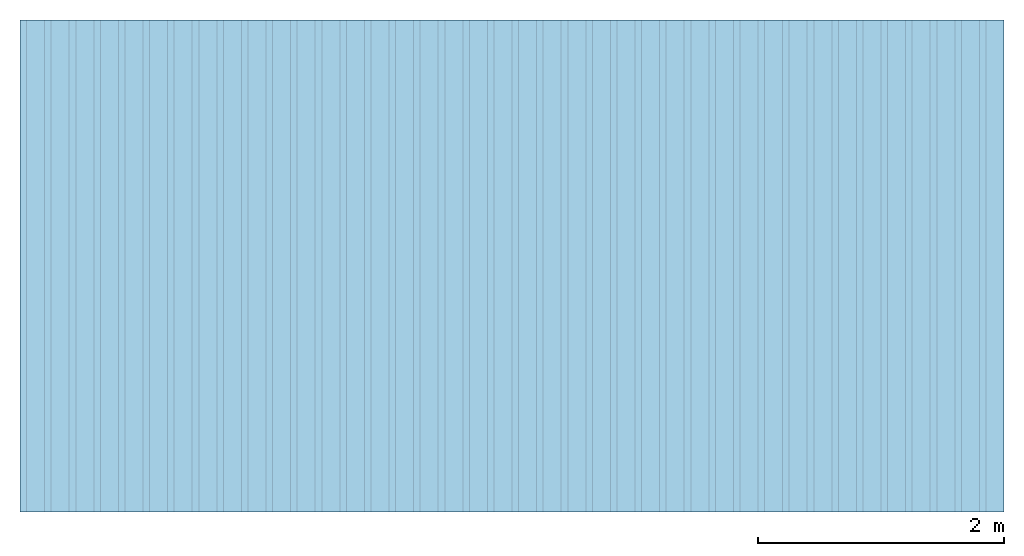
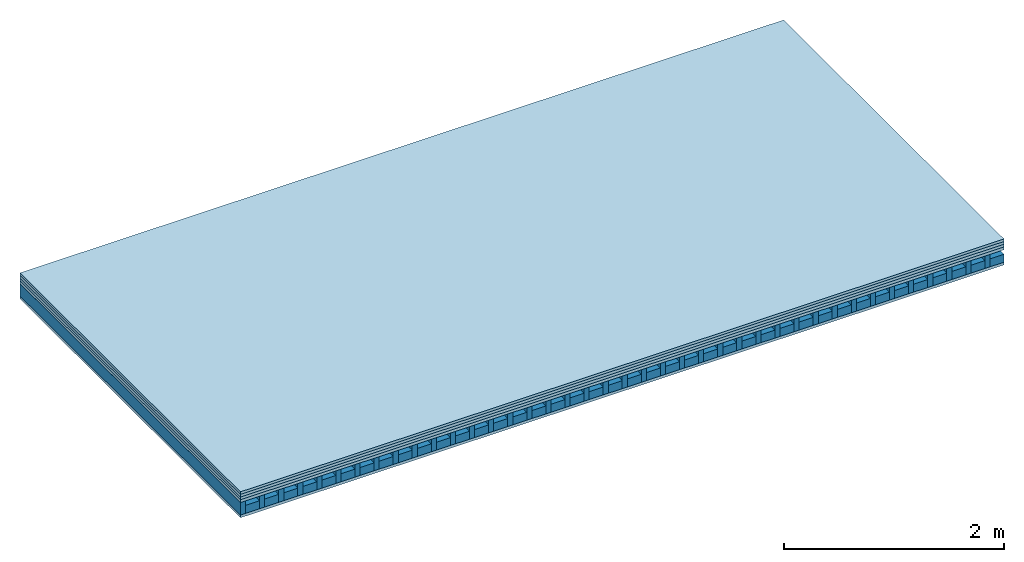
# One storey: 5 plates, 2 members, 1 element without a shape of its own.
"""IFC4 building model written with IfcOpenShell, lengths in metres."""

from ifc_helpers import new_model, si_unit, derived_unit, direction, frame, frame_2d, origin, origin_with_axes, place, context, project, spatial, rectangle, extrude, material, layer, layer_set, type_object, element, aggregate, save


model = new_model("IFC4")

# Units and contexts
plan_context = context("Plan", 3, precision=1e-05, world=origin(), true_north=direction((0.0, 1.0)))
model_context = context("Model", 3, precision=1e-05, world=origin(), true_north=direction((0.0, 1.0)))
ifc_project = project(units=[si_unit("LENGTHUNIT", "METRE"), derived_unit("SOUNDPRESSUREUNIT", [(si_unit("PRESSUREUNIT", "PASCAL", prefix="MICRO"), 0)]), si_unit("ENERGYUNIT", "JOULE", prefix="MEGA"), si_unit("MASSUNIT", "GRAM", prefix="KILO"), derived_unit("THERMALTRANSMITTANCEUNIT", [(si_unit("POWERUNIT", "WATT"), 1), (si_unit("AREAUNIT", "SQUARE_METRE"), -1), (si_unit("THERMODYNAMICTEMPERATUREUNIT", "KELVIN"), -1)]), derived_unit("AREADENSITYUNIT", [(si_unit("MASSUNIT", "GRAM", prefix="KILO"), 1), (si_unit("AREAUNIT", "SQUARE_METRE"), -1)]), derived_unit("USERDEFINED", [(si_unit("ENERGYUNIT", "JOULE", prefix="MEGA"), 1), (si_unit("AREAUNIT", "SQUARE_METRE"), -1)])], contexts=[plan_context, model_context])

# Site, building, storey
site = spatial("IfcSite", under=ifc_project)
building_placement = place(None, origin())
building = spatial("IfcBuilding", under=site, at=building_placement)
storey_placement = place(building_placement, origin())
storey = spatial("IfcBuildingStorey", under=building, at=storey_placement)

# Slab, members, plates
ifc_material_1 = material(Name="P2 ECO", Category="07.015")
ifc_layer_1 = layer(ifc_material_1, 0.028, Name="On-material")
ifc_material_2 = material(Name="EP2, 30mm")
ifc_layer_2 = layer(ifc_material_2, 0.03, Name="Impact sound insulation")
ifc_material_3 = material(Category="03.011")
ifc_layer_3 = layer(ifc_material_3, 0.03, Name="on Supporting structure")
ifc_material_4 = material(Name="box-element sheathing above")
ifc_layer_4 = layer(ifc_material_4, 0.031, Name="Sub-floor")
ifc_layer_5 = layer(None, 0.138, Name="Supporting structure")
ifc_material_5 = material(Name="box-element sheathing below")
ifc_layer_6 = layer(ifc_material_5, 0.031, Name="Lower layer 1")
ifc_layer_set = layer_set([ifc_layer_1, ifc_layer_2, ifc_layer_3, ifc_layer_4, ifc_layer_5, ifc_layer_6])
slab_type = type_object("IfcSlabType", Name="A1463", PredefinedType="NOTDEFINED", material=ifc_layer_set)
slab_placement = place(None, frame((0.0, 0.0, 0.0), z_axis=(0.0, 0.0, -1.0), x_axis=(1.0, 0.0, 0.0)))
slab = element("IfcSlab", 1, at=slab_placement, inside=storey, type_object=slab_type, material=ifc_layer_set, Name="Slab #1")
ifc_material_6 = material(Name="box-element LKE 12")
member_1_placement = place(slab_placement, origin())
member_1 = element("IfcMember", 2, at=member_1_placement, material=ifc_material_6, Name="Supporting structure", context=plan_context, shape_type="SweptSolid", body=[
    extrude(rectangle(XDim=0.054, YDim=0.138, at=frame_2d((0.027, 0.069), x_axis=(1.0, 0.0))), frame((0.0, 4.0, 0.119), z_axis=(0.0, -1.0, 0.0), x_axis=(1.0, 0.0, 0.0)), (0.0, 0.0, 1.0), 4.0),
    extrude(rectangle(XDim=0.054, YDim=0.138, at=frame_2d((0.027, 0.069), x_axis=(1.0, 0.0))), frame((0.2, 4.0, 0.119), z_axis=(0.0, -1.0, 0.0), x_axis=(1.0, 0.0, 0.0)), (0.0, 0.0, 1.0), 4.0),
    extrude(rectangle(XDim=0.054, YDim=0.138, at=frame_2d((0.027, 0.069), x_axis=(1.0, 0.0))), frame((0.4, 4.0, 0.119), z_axis=(0.0, -1.0, 0.0), x_axis=(1.0, 0.0, 0.0)), (0.0, 0.0, 1.0), 4.0),
    extrude(rectangle(XDim=0.054, YDim=0.138, at=frame_2d((0.027, 0.069), x_axis=(1.0, 0.0))), frame((0.6, 4.0, 0.119), z_axis=(0.0, -1.0, 0.0), x_axis=(1.0, 0.0, 0.0)), (0.0, 0.0, 1.0), 4.0),
    extrude(rectangle(XDim=0.054, YDim=0.138, at=frame_2d((0.027, 0.069), x_axis=(1.0, 0.0))), frame((0.8, 4.0, 0.119), z_axis=(0.0, -1.0, 0.0), x_axis=(1.0, 0.0, 0.0)), (0.0, 0.0, 1.0), 4.0),
    extrude(rectangle(XDim=0.054, YDim=0.138, at=frame_2d((0.027, 0.069), x_axis=(1.0, 0.0))), frame((1.0, 4.0, 0.119), z_axis=(0.0, -1.0, 0.0), x_axis=(1.0, 0.0, 0.0)), (0.0, 0.0, 1.0), 4.0),
    extrude(rectangle(XDim=0.054, YDim=0.138, at=frame_2d((0.027, 0.069), x_axis=(1.0, 0.0))), frame((1.2, 4.0, 0.119), z_axis=(0.0, -1.0, 0.0), x_axis=(1.0, 0.0, 0.0)), (0.0, 0.0, 1.0), 4.0),
    extrude(rectangle(XDim=0.054, YDim=0.138, at=frame_2d((0.027, 0.069), x_axis=(1.0, 0.0))), frame((1.4, 4.0, 0.119), z_axis=(0.0, -1.0, 0.0), x_axis=(1.0, 0.0, 0.0)), (0.0, 0.0, 1.0), 4.0),
    extrude(rectangle(XDim=0.054, YDim=0.138, at=frame_2d((0.027, 0.069), x_axis=(1.0, 0.0))), frame((1.6, 4.0, 0.119), z_axis=(0.0, -1.0, 0.0), x_axis=(1.0, 0.0, 0.0)), (0.0, 0.0, 1.0), 4.0),
    extrude(rectangle(XDim=0.054, YDim=0.138, at=frame_2d((0.027, 0.069), x_axis=(1.0, 0.0))), frame((1.8, 4.0, 0.119), z_axis=(0.0, -1.0, 0.0), x_axis=(1.0, 0.0, 0.0)), (0.0, 0.0, 1.0), 4.0),
    extrude(rectangle(XDim=0.054, YDim=0.138, at=frame_2d((0.027, 0.069), x_axis=(1.0, 0.0))), frame((2.0, 4.0, 0.119), z_axis=(0.0, -1.0, 0.0), x_axis=(1.0, 0.0, 0.0)), (0.0, 0.0, 1.0), 4.0),
    extrude(rectangle(XDim=0.054, YDim=0.138, at=frame_2d((0.027, 0.069), x_axis=(1.0, 0.0))), frame((2.2, 4.0, 0.119), z_axis=(0.0, -1.0, 0.0), x_axis=(1.0, 0.0, 0.0)), (0.0, 0.0, 1.0), 4.0),
    extrude(rectangle(XDim=0.054, YDim=0.138, at=frame_2d((0.027, 0.069), x_axis=(1.0, 0.0))), frame((2.4, 4.0, 0.119), z_axis=(0.0, -1.0, 0.0), x_axis=(1.0, 0.0, 0.0)), (0.0, 0.0, 1.0), 4.0),
    extrude(rectangle(XDim=0.054, YDim=0.138, at=frame_2d((0.027, 0.069), x_axis=(1.0, 0.0))), frame((2.6, 4.0, 0.119), z_axis=(0.0, -1.0, 0.0), x_axis=(1.0, 0.0, 0.0)), (0.0, 0.0, 1.0), 4.0),
    extrude(rectangle(XDim=0.054, YDim=0.138, at=frame_2d((0.027, 0.069), x_axis=(1.0, 0.0))), frame((2.8, 4.0, 0.119), z_axis=(0.0, -1.0, 0.0), x_axis=(1.0, 0.0, 0.0)), (0.0, 0.0, 1.0), 4.0),
    extrude(rectangle(XDim=0.054, YDim=0.138, at=frame_2d((0.027, 0.069), x_axis=(1.0, 0.0))), frame((3.0, 4.0, 0.119), z_axis=(0.0, -1.0, 0.0), x_axis=(1.0, 0.0, 0.0)), (0.0, 0.0, 1.0), 4.0),
    extrude(rectangle(XDim=0.054, YDim=0.138, at=frame_2d((0.027, 0.069), x_axis=(1.0, 0.0))), frame((3.2, 4.0, 0.119), z_axis=(0.0, -1.0, 0.0), x_axis=(1.0, 0.0, 0.0)), (0.0, 0.0, 1.0), 4.0),
    extrude(rectangle(XDim=0.054, YDim=0.138, at=frame_2d((0.027, 0.069), x_axis=(1.0, 0.0))), frame((3.4, 4.0, 0.119), z_axis=(0.0, -1.0, 0.0), x_axis=(1.0, 0.0, 0.0)), (0.0, 0.0, 1.0), 4.0),
    extrude(rectangle(XDim=0.054, YDim=0.138, at=frame_2d((0.027, 0.069), x_axis=(1.0, 0.0))), frame((3.6, 4.0, 0.119), z_axis=(0.0, -1.0, 0.0), x_axis=(1.0, 0.0, 0.0)), (0.0, 0.0, 1.0), 4.0),
    extrude(rectangle(XDim=0.054, YDim=0.138, at=frame_2d((0.027, 0.069), x_axis=(1.0, 0.0))), frame((3.8, 4.0, 0.119), z_axis=(0.0, -1.0, 0.0), x_axis=(1.0, 0.0, 0.0)), (0.0, 0.0, 1.0), 4.0),
    extrude(rectangle(XDim=0.054, YDim=0.138, at=frame_2d((0.027, 0.069), x_axis=(1.0, 0.0))), frame((4.0, 4.0, 0.119), z_axis=(0.0, -1.0, 0.0), x_axis=(1.0, 0.0, 0.0)), (0.0, 0.0, 1.0), 4.0),
    extrude(rectangle(XDim=0.054, YDim=0.138, at=frame_2d((0.027, 0.069), x_axis=(1.0, 0.0))), frame((4.2, 4.0, 0.119), z_axis=(0.0, -1.0, 0.0), x_axis=(1.0, 0.0, 0.0)), (0.0, 0.0, 1.0), 4.0),
    extrude(rectangle(XDim=0.054, YDim=0.138, at=frame_2d((0.027, 0.069), x_axis=(1.0, 0.0))), frame((4.4, 4.0, 0.119), z_axis=(0.0, -1.0, 0.0), x_axis=(1.0, 0.0, 0.0)), (0.0, 0.0, 1.0), 4.0),
    extrude(rectangle(XDim=0.054, YDim=0.138, at=frame_2d((0.027, 0.069), x_axis=(1.0, 0.0))), frame((4.6, 4.0, 0.119), z_axis=(0.0, -1.0, 0.0), x_axis=(1.0, 0.0, 0.0)), (0.0, 0.0, 1.0), 4.0),
    extrude(rectangle(XDim=0.054, YDim=0.138, at=frame_2d((0.027, 0.069), x_axis=(1.0, 0.0))), frame((4.8, 4.0, 0.119), z_axis=(0.0, -1.0, 0.0), x_axis=(1.0, 0.0, 0.0)), (0.0, 0.0, 1.0), 4.0),
    extrude(rectangle(XDim=0.054, YDim=0.138, at=frame_2d((0.027, 0.069), x_axis=(1.0, 0.0))), frame((5.0, 4.0, 0.119), z_axis=(0.0, -1.0, 0.0), x_axis=(1.0, 0.0, 0.0)), (0.0, 0.0, 1.0), 4.0),
    extrude(rectangle(XDim=0.054, YDim=0.138, at=frame_2d((0.027, 0.069), x_axis=(1.0, 0.0))), frame((5.2, 4.0, 0.119), z_axis=(0.0, -1.0, 0.0), x_axis=(1.0, 0.0, 0.0)), (0.0, 0.0, 1.0), 4.0),
    extrude(rectangle(XDim=0.054, YDim=0.138, at=frame_2d((0.027, 0.069), x_axis=(1.0, 0.0))), frame((5.4, 4.0, 0.119), z_axis=(0.0, -1.0, 0.0), x_axis=(1.0, 0.0, 0.0)), (0.0, 0.0, 1.0), 4.0),
    extrude(rectangle(XDim=0.054, YDim=0.138, at=frame_2d((0.027, 0.069), x_axis=(1.0, 0.0))), frame((5.6, 4.0, 0.119), z_axis=(0.0, -1.0, 0.0), x_axis=(1.0, 0.0, 0.0)), (0.0, 0.0, 1.0), 4.0),
    extrude(rectangle(XDim=0.054, YDim=0.138, at=frame_2d((0.027, 0.069), x_axis=(1.0, 0.0))), frame((5.8, 4.0, 0.119), z_axis=(0.0, -1.0, 0.0), x_axis=(1.0, 0.0, 0.0)), (0.0, 0.0, 1.0), 4.0),
    extrude(rectangle(XDim=0.054, YDim=0.138, at=frame_2d((0.027, 0.069), x_axis=(1.0, 0.0))), frame((6.0, 4.0, 0.119), z_axis=(0.0, -1.0, 0.0), x_axis=(1.0, 0.0, 0.0)), (0.0, 0.0, 1.0), 4.0),
    extrude(rectangle(XDim=0.054, YDim=0.138, at=frame_2d((0.027, 0.069), x_axis=(1.0, 0.0))), frame((6.2, 4.0, 0.119), z_axis=(0.0, -1.0, 0.0), x_axis=(1.0, 0.0, 0.0)), (0.0, 0.0, 1.0), 4.0),
    extrude(rectangle(XDim=0.054, YDim=0.138, at=frame_2d((0.027, 0.069), x_axis=(1.0, 0.0))), frame((6.4, 4.0, 0.119), z_axis=(0.0, -1.0, 0.0), x_axis=(1.0, 0.0, 0.0)), (0.0, 0.0, 1.0), 4.0),
    extrude(rectangle(XDim=0.054, YDim=0.138, at=frame_2d((0.027, 0.069), x_axis=(1.0, 0.0))), frame((6.6, 4.0, 0.119), z_axis=(0.0, -1.0, 0.0), x_axis=(1.0, 0.0, 0.0)), (0.0, 0.0, 1.0), 4.0),
    extrude(rectangle(XDim=0.054, YDim=0.138, at=frame_2d((0.027, 0.069), x_axis=(1.0, 0.0))), frame((6.8, 4.0, 0.119), z_axis=(0.0, -1.0, 0.0), x_axis=(1.0, 0.0, 0.0)), (0.0, 0.0, 1.0), 4.0),
    extrude(rectangle(XDim=0.054, YDim=0.138, at=frame_2d((0.027, 0.069), x_axis=(1.0, 0.0))), frame((7.0, 4.0, 0.119), z_axis=(0.0, -1.0, 0.0), x_axis=(1.0, 0.0, 0.0)), (0.0, 0.0, 1.0), 4.0),
    extrude(rectangle(XDim=0.054, YDim=0.138, at=frame_2d((0.027, 0.069), x_axis=(1.0, 0.0))), frame((7.2, 4.0, 0.119), z_axis=(0.0, -1.0, 0.0), x_axis=(1.0, 0.0, 0.0)), (0.0, 0.0, 1.0), 4.0),
    extrude(rectangle(XDim=0.054, YDim=0.138, at=frame_2d((0.027, 0.069), x_axis=(1.0, 0.0))), frame((7.4, 4.0, 0.119), z_axis=(0.0, -1.0, 0.0), x_axis=(1.0, 0.0, 0.0)), (0.0, 0.0, 1.0), 4.0),
    extrude(rectangle(XDim=0.054, YDim=0.138, at=frame_2d((0.027, 0.069), x_axis=(1.0, 0.0))), frame((7.6, 4.0, 0.119), z_axis=(0.0, -1.0, 0.0), x_axis=(1.0, 0.0, 0.0)), (0.0, 0.0, 1.0), 4.0),
    extrude(rectangle(XDim=0.054, YDim=0.138, at=frame_2d((0.027, 0.069), x_axis=(1.0, 0.0))), frame((7.8, 4.0, 0.119), z_axis=(0.0, -1.0, 0.0), x_axis=(1.0, 0.0, 0.0)), (0.0, 0.0, 1.0), 4.0),
])
ifc_material_7 = material(Name="Damper and limestone LKE 12")
member_2_placement = place(slab_placement, origin())
member_2 = element("IfcMember", 3, at=member_2_placement, material=ifc_material_7, Name="in supporting structure", context=plan_context, shape_type="SweptSolid", body=[
    extrude(rectangle(XDim=0.146, YDim=0.088, at=frame_2d((0.073, 0.044), x_axis=(1.0, 0.0))), frame((0.054, 4.0, 0.169), z_axis=(0.0, -1.0, 0.0), x_axis=(1.0, 0.0, 0.0)), (0.0, 0.0, 1.0), 4.0),
    extrude(rectangle(XDim=0.146, YDim=0.088, at=frame_2d((0.073, 0.044), x_axis=(1.0, 0.0))), frame((0.254, 4.0, 0.169), z_axis=(0.0, -1.0, 0.0), x_axis=(1.0, 0.0, 0.0)), (0.0, 0.0, 1.0), 4.0),
    extrude(rectangle(XDim=0.146, YDim=0.088, at=frame_2d((0.073, 0.044), x_axis=(1.0, 0.0))), frame((0.454, 4.0, 0.169), z_axis=(0.0, -1.0, 0.0), x_axis=(1.0, 0.0, 0.0)), (0.0, 0.0, 1.0), 4.0),
    extrude(rectangle(XDim=0.146, YDim=0.088, at=frame_2d((0.073, 0.044), x_axis=(1.0, 0.0))), frame((0.654, 4.0, 0.169), z_axis=(0.0, -1.0, 0.0), x_axis=(1.0, 0.0, 0.0)), (0.0, 0.0, 1.0), 4.0),
    extrude(rectangle(XDim=0.146, YDim=0.088, at=frame_2d((0.073, 0.044), x_axis=(1.0, 0.0))), frame((0.854, 4.0, 0.169), z_axis=(0.0, -1.0, 0.0), x_axis=(1.0, 0.0, 0.0)), (0.0, 0.0, 1.0), 4.0),
    extrude(rectangle(XDim=0.146, YDim=0.088, at=frame_2d((0.073, 0.044), x_axis=(1.0, 0.0))), frame((1.054, 4.0, 0.169), z_axis=(0.0, -1.0, 0.0), x_axis=(1.0, 0.0, 0.0)), (0.0, 0.0, 1.0), 4.0),
    extrude(rectangle(XDim=0.146, YDim=0.088, at=frame_2d((0.073, 0.044), x_axis=(1.0, 0.0))), frame((1.254, 4.0, 0.169), z_axis=(0.0, -1.0, 0.0), x_axis=(1.0, 0.0, 0.0)), (0.0, 0.0, 1.0), 4.0),
    extrude(rectangle(XDim=0.146, YDim=0.088, at=frame_2d((0.073, 0.044), x_axis=(1.0, 0.0))), frame((1.454, 4.0, 0.169), z_axis=(0.0, -1.0, 0.0), x_axis=(1.0, 0.0, 0.0)), (0.0, 0.0, 1.0), 4.0),
    extrude(rectangle(XDim=0.146, YDim=0.088, at=frame_2d((0.073, 0.044), x_axis=(1.0, 0.0))), frame((1.654, 4.0, 0.169), z_axis=(0.0, -1.0, 0.0), x_axis=(1.0, 0.0, 0.0)), (0.0, 0.0, 1.0), 4.0),
    extrude(rectangle(XDim=0.146, YDim=0.088, at=frame_2d((0.073, 0.044), x_axis=(1.0, 0.0))), frame((1.854, 4.0, 0.169), z_axis=(0.0, -1.0, 0.0), x_axis=(1.0, 0.0, 0.0)), (0.0, 0.0, 1.0), 4.0),
    extrude(rectangle(XDim=0.146, YDim=0.088, at=frame_2d((0.073, 0.044), x_axis=(1.0, 0.0))), frame((2.054, 4.0, 0.169), z_axis=(0.0, -1.0, 0.0), x_axis=(1.0, 0.0, 0.0)), (0.0, 0.0, 1.0), 4.0),
    extrude(rectangle(XDim=0.146, YDim=0.088, at=frame_2d((0.073, 0.044), x_axis=(1.0, 0.0))), frame((2.254, 4.0, 0.169), z_axis=(0.0, -1.0, 0.0), x_axis=(1.0, 0.0, 0.0)), (0.0, 0.0, 1.0), 4.0),
    extrude(rectangle(XDim=0.146, YDim=0.088, at=frame_2d((0.073, 0.044), x_axis=(1.0, 0.0))), frame((2.454, 4.0, 0.169), z_axis=(0.0, -1.0, 0.0), x_axis=(1.0, 0.0, 0.0)), (0.0, 0.0, 1.0), 4.0),
    extrude(rectangle(XDim=0.146, YDim=0.088, at=frame_2d((0.073, 0.044), x_axis=(1.0, 0.0))), frame((2.654, 4.0, 0.169), z_axis=(0.0, -1.0, 0.0), x_axis=(1.0, 0.0, 0.0)), (0.0, 0.0, 1.0), 4.0),
    extrude(rectangle(XDim=0.146, YDim=0.088, at=frame_2d((0.073, 0.044), x_axis=(1.0, 0.0))), frame((2.854, 4.0, 0.169), z_axis=(0.0, -1.0, 0.0), x_axis=(1.0, 0.0, 0.0)), (0.0, 0.0, 1.0), 4.0),
    extrude(rectangle(XDim=0.146, YDim=0.088, at=frame_2d((0.073, 0.044), x_axis=(1.0, 0.0))), frame((3.054, 4.0, 0.169), z_axis=(0.0, -1.0, 0.0), x_axis=(1.0, 0.0, 0.0)), (0.0, 0.0, 1.0), 4.0),
    extrude(rectangle(XDim=0.146, YDim=0.088, at=frame_2d((0.073, 0.044), x_axis=(1.0, 0.0))), frame((3.254, 4.0, 0.169), z_axis=(0.0, -1.0, 0.0), x_axis=(1.0, 0.0, 0.0)), (0.0, 0.0, 1.0), 4.0),
    extrude(rectangle(XDim=0.146, YDim=0.088, at=frame_2d((0.073, 0.044), x_axis=(1.0, 0.0))), frame((3.454, 4.0, 0.169), z_axis=(0.0, -1.0, 0.0), x_axis=(1.0, 0.0, 0.0)), (0.0, 0.0, 1.0), 4.0),
    extrude(rectangle(XDim=0.146, YDim=0.088, at=frame_2d((0.073, 0.044), x_axis=(1.0, 0.0))), frame((3.654, 4.0, 0.169), z_axis=(0.0, -1.0, 0.0), x_axis=(1.0, 0.0, 0.0)), (0.0, 0.0, 1.0), 4.0),
    extrude(rectangle(XDim=0.146, YDim=0.088, at=frame_2d((0.073, 0.044), x_axis=(1.0, 0.0))), frame((3.854, 4.0, 0.169), z_axis=(0.0, -1.0, 0.0), x_axis=(1.0, 0.0, 0.0)), (0.0, 0.0, 1.0), 4.0),
    extrude(rectangle(XDim=0.146, YDim=0.088, at=frame_2d((0.073, 0.044), x_axis=(1.0, 0.0))), frame((4.054, 4.0, 0.169), z_axis=(0.0, -1.0, 0.0), x_axis=(1.0, 0.0, 0.0)), (0.0, 0.0, 1.0), 4.0),
    extrude(rectangle(XDim=0.146, YDim=0.088, at=frame_2d((0.073, 0.044), x_axis=(1.0, 0.0))), frame((4.254, 4.0, 0.169), z_axis=(0.0, -1.0, 0.0), x_axis=(1.0, 0.0, 0.0)), (0.0, 0.0, 1.0), 4.0),
    extrude(rectangle(XDim=0.146, YDim=0.088, at=frame_2d((0.073, 0.044), x_axis=(1.0, 0.0))), frame((4.454, 4.0, 0.169), z_axis=(0.0, -1.0, 0.0), x_axis=(1.0, 0.0, 0.0)), (0.0, 0.0, 1.0), 4.0),
    extrude(rectangle(XDim=0.146, YDim=0.088, at=frame_2d((0.073, 0.044), x_axis=(1.0, 0.0))), frame((4.654, 4.0, 0.169), z_axis=(0.0, -1.0, 0.0), x_axis=(1.0, 0.0, 0.0)), (0.0, 0.0, 1.0), 4.0),
    extrude(rectangle(XDim=0.146, YDim=0.088, at=frame_2d((0.073, 0.044), x_axis=(1.0, 0.0))), frame((4.854, 4.0, 0.169), z_axis=(0.0, -1.0, 0.0), x_axis=(1.0, 0.0, 0.0)), (0.0, 0.0, 1.0), 4.0),
    extrude(rectangle(XDim=0.146, YDim=0.088, at=frame_2d((0.073, 0.044), x_axis=(1.0, 0.0))), frame((5.054, 4.0, 0.169), z_axis=(0.0, -1.0, 0.0), x_axis=(1.0, 0.0, 0.0)), (0.0, 0.0, 1.0), 4.0),
    extrude(rectangle(XDim=0.146, YDim=0.088, at=frame_2d((0.073, 0.044), x_axis=(1.0, 0.0))), frame((5.254, 4.0, 0.169), z_axis=(0.0, -1.0, 0.0), x_axis=(1.0, 0.0, 0.0)), (0.0, 0.0, 1.0), 4.0),
    extrude(rectangle(XDim=0.146, YDim=0.088, at=frame_2d((0.073, 0.044), x_axis=(1.0, 0.0))), frame((5.454, 4.0, 0.169), z_axis=(0.0, -1.0, 0.0), x_axis=(1.0, 0.0, 0.0)), (0.0, 0.0, 1.0), 4.0),
    extrude(rectangle(XDim=0.146, YDim=0.088, at=frame_2d((0.073, 0.044), x_axis=(1.0, 0.0))), frame((5.654, 4.0, 0.169), z_axis=(0.0, -1.0, 0.0), x_axis=(1.0, 0.0, 0.0)), (0.0, 0.0, 1.0), 4.0),
    extrude(rectangle(XDim=0.146, YDim=0.088, at=frame_2d((0.073, 0.044), x_axis=(1.0, 0.0))), frame((5.854, 4.0, 0.169), z_axis=(0.0, -1.0, 0.0), x_axis=(1.0, 0.0, 0.0)), (0.0, 0.0, 1.0), 4.0),
    extrude(rectangle(XDim=0.146, YDim=0.088, at=frame_2d((0.073, 0.044), x_axis=(1.0, 0.0))), frame((6.054, 4.0, 0.169), z_axis=(0.0, -1.0, 0.0), x_axis=(1.0, 0.0, 0.0)), (0.0, 0.0, 1.0), 4.0),
    extrude(rectangle(XDim=0.146, YDim=0.088, at=frame_2d((0.073, 0.044), x_axis=(1.0, 0.0))), frame((6.254, 4.0, 0.169), z_axis=(0.0, -1.0, 0.0), x_axis=(1.0, 0.0, 0.0)), (0.0, 0.0, 1.0), 4.0),
    extrude(rectangle(XDim=0.146, YDim=0.088, at=frame_2d((0.073, 0.044), x_axis=(1.0, 0.0))), frame((6.454, 4.0, 0.169), z_axis=(0.0, -1.0, 0.0), x_axis=(1.0, 0.0, 0.0)), (0.0, 0.0, 1.0), 4.0),
    extrude(rectangle(XDim=0.146, YDim=0.088, at=frame_2d((0.073, 0.044), x_axis=(1.0, 0.0))), frame((6.654, 4.0, 0.169), z_axis=(0.0, -1.0, 0.0), x_axis=(1.0, 0.0, 0.0)), (0.0, 0.0, 1.0), 4.0),
    extrude(rectangle(XDim=0.146, YDim=0.088, at=frame_2d((0.073, 0.044), x_axis=(1.0, 0.0))), frame((6.854, 4.0, 0.169), z_axis=(0.0, -1.0, 0.0), x_axis=(1.0, 0.0, 0.0)), (0.0, 0.0, 1.0), 4.0),
    extrude(rectangle(XDim=0.146, YDim=0.088, at=frame_2d((0.073, 0.044), x_axis=(1.0, 0.0))), frame((7.054, 4.0, 0.169), z_axis=(0.0, -1.0, 0.0), x_axis=(1.0, 0.0, 0.0)), (0.0, 0.0, 1.0), 4.0),
    extrude(rectangle(XDim=0.146, YDim=0.088, at=frame_2d((0.073, 0.044), x_axis=(1.0, 0.0))), frame((7.254, 4.0, 0.169), z_axis=(0.0, -1.0, 0.0), x_axis=(1.0, 0.0, 0.0)), (0.0, 0.0, 1.0), 4.0),
    extrude(rectangle(XDim=0.146, YDim=0.088, at=frame_2d((0.073, 0.044), x_axis=(1.0, 0.0))), frame((7.454, 4.0, 0.169), z_axis=(0.0, -1.0, 0.0), x_axis=(1.0, 0.0, 0.0)), (0.0, 0.0, 1.0), 4.0),
    extrude(rectangle(XDim=0.146, YDim=0.088, at=frame_2d((0.073, 0.044), x_axis=(1.0, 0.0))), frame((7.654, 4.0, 0.169), z_axis=(0.0, -1.0, 0.0), x_axis=(1.0, 0.0, 0.0)), (0.0, 0.0, 1.0), 4.0),
    extrude(rectangle(XDim=0.146, YDim=0.088, at=frame_2d((0.073, 0.044), x_axis=(1.0, 0.0))), frame((7.854, 4.0, 0.169), z_axis=(0.0, -1.0, 0.0), x_axis=(1.0, 0.0, 0.0)), (0.0, 0.0, 1.0), 4.0),
])
plate_1_placement = place(slab_placement, origin())
plate_1 = element("IfcPlate", 4, at=plate_1_placement, material=ifc_material_1, Name="On-material", context=plan_context, shape_type="SweptSolid", body=[
    extrude(rectangle(XDim=8.0, YDim=4.0, at=frame_2d((4.0, 2.0), x_axis=(1.0, 0.0))), origin_with_axes(), (0.0, 0.0, 1.0), 0.028),
])
plate_2_placement = place(slab_placement, origin())
plate_2 = element("IfcPlate", 5, at=plate_2_placement, material=ifc_material_2, Name="Impact sound insulation", context=plan_context, shape_type="SweptSolid", body=[
    extrude(rectangle(XDim=8.0, YDim=4.0, at=frame_2d((4.0, 2.0), x_axis=(1.0, 0.0))), frame((0.0, 0.0, 0.028), z_axis=(0.0, 0.0, 1.0), x_axis=(1.0, 0.0, 0.0)), (0.0, 0.0, 1.0), 0.03),
])
plate_3_placement = place(slab_placement, origin())
plate_3 = element("IfcPlate", 6, at=plate_3_placement, material=ifc_material_3, Name="on Supporting structure", context=plan_context, shape_type="SweptSolid", body=[
    extrude(rectangle(XDim=8.0, YDim=4.0, at=frame_2d((4.0, 2.0), x_axis=(1.0, 0.0))), frame((0.0, 0.0, 0.058), z_axis=(0.0, 0.0, 1.0), x_axis=(1.0, 0.0, 0.0)), (0.0, 0.0, 1.0), 0.03),
])
plate_4_placement = place(slab_placement, origin())
plate_4 = element("IfcPlate", 7, at=plate_4_placement, material=ifc_material_4, Name="Sub-floor", context=plan_context, shape_type="SweptSolid", body=[
    extrude(rectangle(XDim=8.0, YDim=4.0, at=frame_2d((4.0, 2.0), x_axis=(1.0, 0.0))), frame((0.0, 0.0, 0.088), z_axis=(0.0, 0.0, 1.0), x_axis=(1.0, 0.0, 0.0)), (0.0, 0.0, 1.0), 0.031),
])
plate_5_placement = place(slab_placement, origin())
plate_5 = element("IfcPlate", 8, at=plate_5_placement, material=ifc_material_5, Name="Lower layer 1", context=plan_context, shape_type="SweptSolid", body=[
    extrude(rectangle(XDim=8.0, YDim=4.0, at=frame_2d((4.0, 2.0), x_axis=(1.0, 0.0))), frame((0.0, 0.0, 0.257), z_axis=(0.0, 0.0, 1.0), x_axis=(1.0, 0.0, 0.0)), (0.0, 0.0, 1.0), 0.031),
])
aggregate(slab, [plate_1, plate_2, plate_3, plate_4, member_1, member_2, plate_5])

save(model, "model.ifc")
